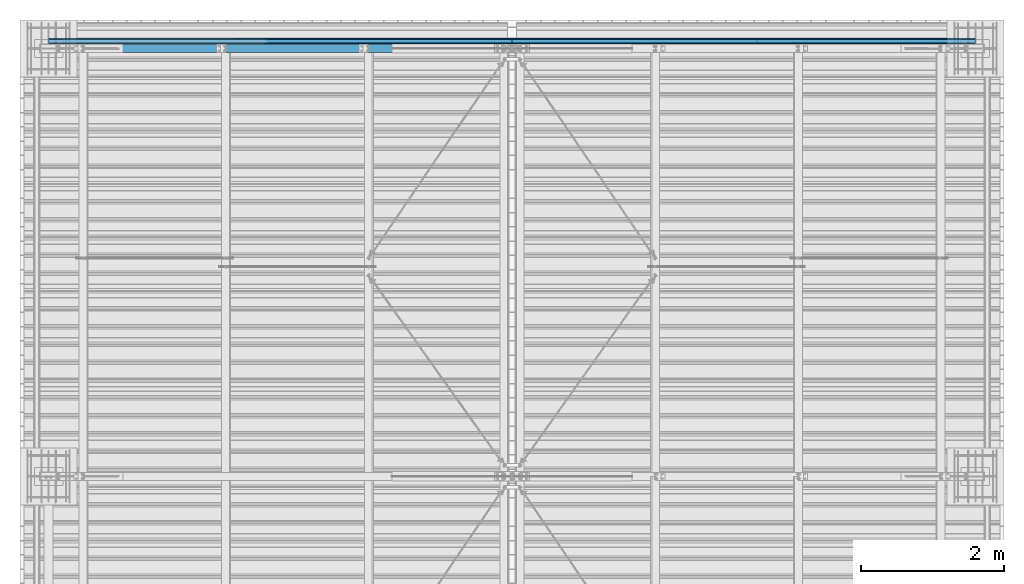
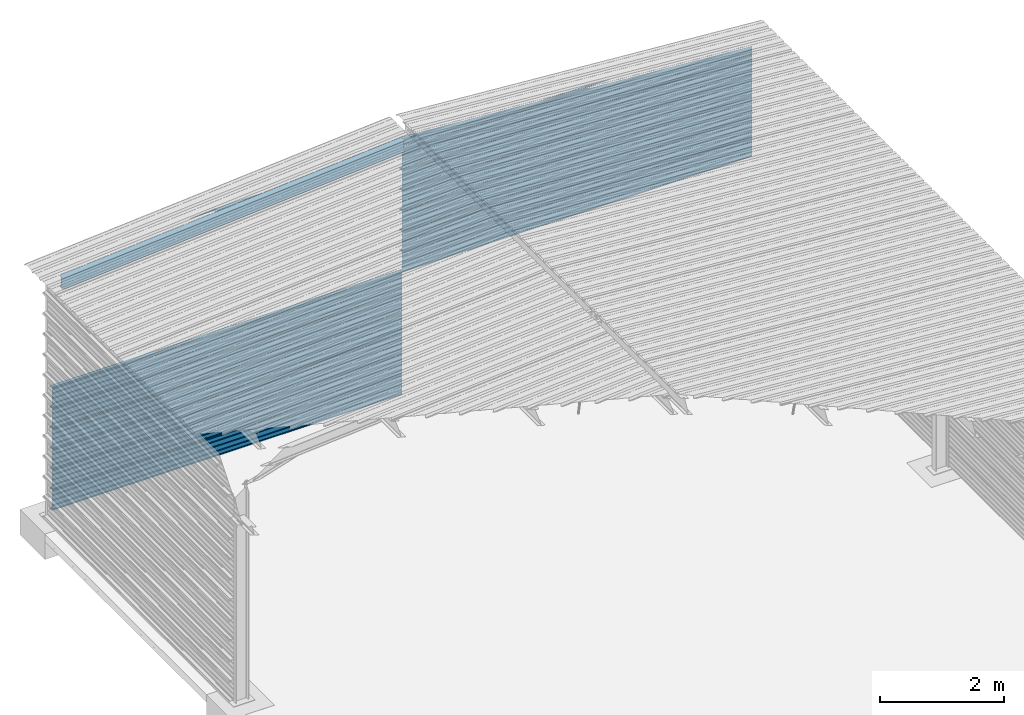
# One storey, part 20 of 70: 15 beams, 15 elements without a shape of their own.
"""IFC2X3 building model written with IfcOpenShell, lengths in millimetres."""

from ifc_helpers import new_model, si_unit, frame, origin_with_axes, origin_2d_with_axis, place, context, subcontext, project, spatial, polyline, i_section, outline, extrude, clip, halfspace, material, type_object, element, aggregate, save


model = new_model("IFC2X3")

# Units and contexts
model_context = context("Model", 3, precision=1e-05, world=origin_with_axes())
body_context = subcontext(model_context, "Body", "Model", "MODEL_VIEW")
ifc_project = project(units=[si_unit("LENGTHUNIT", "METRE", prefix="MILLI"), si_unit("AREAUNIT", "SQUARE_METRE"), si_unit("VOLUMEUNIT", "CUBIC_METRE"), si_unit("MASSUNIT", "GRAM", prefix="KILO"), si_unit("TIMEUNIT", "SECOND"), si_unit("PLANEANGLEUNIT", "RADIAN"), si_unit("SOLIDANGLEUNIT", "STERADIAN"), si_unit("THERMODYNAMICTEMPERATUREUNIT", "DEGREE_CELSIUS"), si_unit("LUMINOUSINTENSITYUNIT", "LUMEN")], contexts=[model_context])

# Site, building, storey
site_placement = place(None, origin_with_axes())
site = spatial("IfcSite", under=ifc_project, at=site_placement, CompositionType="ELEMENT")
building_placement = place(site_placement, origin_with_axes())
building = spatial("IfcBuilding", under=site, at=building_placement, Name="Undefined", CompositionType="ELEMENT")
storey_placement = place(building_placement, origin_with_axes())
storey = spatial("IfcBuildingStorey", under=building, at=storey_placement, Name="Undefined", CompositionType="ELEMENT", Elevation=0.0)

# Assembly, beam
assembly_1_placement = place(storey_placement, origin_with_axes())
assembly_1 = element("IfcElementAssembly", 1, at=assembly_1_placement, inside=storey, Name="Steel Assembly", AssemblyPlace="NOTDEFINED", PredefinedType="RIGID_FRAME")
ifc_material = material(Name="STEEL/S235JR")
beam_type_1 = type_object("IfcBeamType", Name="400", PredefinedType="NOTDEFINED")
beam_1_placement = place(assembly_1_placement, frame((0.0, 24105.5035213674, 5018.25), z_axis=(0.0, 1.0, 0.0), x_axis=(1.0, 0.0, 0.0)))
beam_1 = element("IfcBeam", 2, at=beam_1_placement, type_object=beam_type_1, material=ifc_material, ObjectType="400", context=body_context, shape_type="Clipping", body=[
    clip(extrude(outline(polyline([(218.25, -24.994083404541), (214.25, -31.8999996185303), (214.25, -45.5), (199.75, -45.5), (194.25, -42.5), (188.75, -45.5), (124.25, -45.5), (114.25, -41.5), (104.25, -45.5), (24.25, -45.5), (14.25, -41.5), (4.25, -45.5), (-75.75, -45.5), (-85.75, -41.5), (-95.75, -45.5), (-160.25, -45.5), (-165.75, -42.5), (-171.25, -45.5), (-185.75, -45.5), (-185.75, -30.711540222168), (-181.75, -23.8111782073975), (-181.75, 23.311637878418), (-185.75, 30.2119998931885), (-185.75, 44.5), (-217.25, 44.5), (-217.25, 34.7999992370605), (-218.25, 34.7999992370605), (-218.25, 45.5), (-184.75, 45.5), (-184.75, 30.480884552002), (-180.75, 23.5805225372314), (-180.75, -24.0800628662109), (-184.75, -30.9804248809814), (-184.75, -44.5), (-171.504989624023, -44.5), (-165.75, -41.360912322998), (-159.995010375977, -44.5), (-95.9425811767578, -44.5), (-85.75, -40.422966003418), (-75.5574188232422, -44.5), (4.05741739273071, -44.5), (14.25, -40.422966003418), (24.4425830841064, -44.5), (104.057418823242, -44.5), (114.25, -40.422966003418), (124.442581176758, -44.5), (188.495010375977, -44.5), (194.25, -41.360912322998), (200.004989624023, -44.5), (213.25, -44.5), (213.25, -31.6313018798828), (217.25, -24.7253856658936), (217.25, 21.7253856658936), (213.25, 28.6313018798828), (213.25, 42.0), (187.25, 42.0), (187.25, 32.5499992370605), (186.25, 32.5499992370605), (186.25, 43.0), (214.25, 43.0), (214.25, 28.8999996185303), (218.25, 21.994083404541), (218.25, -24.994083404541)])), frame((6500.0, 0.0, 0.0), z_axis=(-1.0, 0.0, 0.0), x_axis=(0.0, -1.0, 0.0)), (0.0, 0.0, 1.0), 6500.0), halfspace(frame((0.0, 418.250001003011, -45.0), z_axis=(-0.0766964990376778, -0.997054485489817, 0.0), x_axis=(0.0, 0.0, 1.0)), False)),
])
aggregate(assembly_1, [beam_1])

assembly_2_placement = place(storey_placement, origin_with_axes())
assembly_2 = element("IfcElementAssembly", 3, at=assembly_2_placement, inside=storey, Name="Steel Assembly", AssemblyPlace="NOTDEFINED", PredefinedType="RIGID_FRAME")
beam_2_placement = place(assembly_2_placement, frame((0.0, 24105.5035213674, 2218.25), z_axis=(0.0, 1.0, 0.0), x_axis=(1.0, 0.0, 0.0)))
beam_2 = element("IfcBeam", 4, at=beam_2_placement, type_object=beam_type_1, material=ifc_material, ObjectType="400", context=body_context, shape_type="SweptSolid", body=[
    extrude(outline(polyline([(218.25, -24.994083404541), (214.25, -31.8999996185303), (214.25, -45.5), (199.75, -45.5), (194.25, -42.5), (188.75, -45.5), (124.25, -45.5), (114.25, -41.5), (104.25, -45.5), (24.25, -45.5), (14.25, -41.5), (4.25, -45.5), (-75.75, -45.5), (-85.75, -41.5), (-95.75, -45.5), (-160.25, -45.5), (-165.75, -42.5), (-171.25, -45.5), (-185.75, -45.5), (-185.75, -30.711540222168), (-181.75, -23.8111782073975), (-181.75, 23.311637878418), (-185.75, 30.2119998931885), (-185.75, 44.5), (-217.25, 44.5), (-217.25, 34.7999992370605), (-218.25, 34.7999992370605), (-218.25, 45.5), (-184.75, 45.5), (-184.75, 30.480884552002), (-180.75, 23.5805225372314), (-180.75, -24.0800628662109), (-184.75, -30.9804248809814), (-184.75, -44.5), (-171.504989624023, -44.5), (-165.75, -41.360912322998), (-159.995010375977, -44.5), (-95.9425811767578, -44.5), (-85.75, -40.422966003418), (-75.5574188232422, -44.5), (4.05741739273071, -44.5), (14.25, -40.422966003418), (24.4425830841064, -44.5), (104.057418823242, -44.5), (114.25, -40.422966003418), (124.442581176758, -44.5), (188.495010375977, -44.5), (194.25, -41.360912322998), (200.004989624023, -44.5), (213.25, -44.5), (213.25, -31.6313018798828), (217.25, -24.7253856658936), (217.25, 21.7253856658936), (213.25, 28.6313018798828), (213.25, 42.0), (187.25, 42.0), (187.25, 32.5499992370605), (186.25, 32.5499992370605), (186.25, 43.0), (214.25, 43.0), (214.25, 28.8999996185303), (218.25, 21.994083404541), (218.25, -24.994083404541)])), frame((6500.0, 0.0, 0.0), z_axis=(-1.0, 0.0, 0.0), x_axis=(0.0, -1.0, 0.0)), (0.0, 0.0, 1.0), 6500.0),
])
aggregate(assembly_2, [beam_2])

assembly_3_placement = place(storey_placement, origin_with_axes())
assembly_3 = element("IfcElementAssembly", 5, at=assembly_3_placement, inside=storey, Name="Steel Assembly", AssemblyPlace="NOTDEFINED", PredefinedType="RIGID_FRAME")
beam_3_placement = place(assembly_3_placement, frame((0.0, 24105.5035213674, 1818.25), z_axis=(0.0, 1.0, 0.0), x_axis=(1.0, 0.0, 0.0)))
beam_3 = element("IfcBeam", 6, at=beam_3_placement, type_object=beam_type_1, material=ifc_material, ObjectType="400", context=body_context, shape_type="SweptSolid", body=[
    extrude(outline(polyline([(218.25, -24.994083404541), (214.25, -31.8999996185303), (214.25, -45.5), (199.75, -45.5), (194.25, -42.5), (188.75, -45.5), (124.25, -45.5), (114.25, -41.5), (104.25, -45.5), (24.25, -45.5), (14.25, -41.5), (4.25, -45.5), (-75.75, -45.5), (-85.75, -41.5), (-95.75, -45.5), (-160.25, -45.5), (-165.75, -42.5), (-171.25, -45.5), (-185.75, -45.5), (-185.75, -30.711540222168), (-181.75, -23.8111782073975), (-181.75, 23.311637878418), (-185.75, 30.2119998931885), (-185.75, 44.5), (-217.25, 44.5), (-217.25, 34.7999992370605), (-218.25, 34.7999992370605), (-218.25, 45.5), (-184.75, 45.5), (-184.75, 30.480884552002), (-180.75, 23.5805225372314), (-180.75, -24.0800628662109), (-184.75, -30.9804248809814), (-184.75, -44.5), (-171.504989624023, -44.5), (-165.75, -41.360912322998), (-159.995010375977, -44.5), (-95.9425811767578, -44.5), (-85.75, -40.422966003418), (-75.5574188232422, -44.5), (4.05741739273071, -44.5), (14.25, -40.422966003418), (24.4425830841064, -44.5), (104.057418823242, -44.5), (114.25, -40.422966003418), (124.442581176758, -44.5), (188.495010375977, -44.5), (194.25, -41.360912322998), (200.004989624023, -44.5), (213.25, -44.5), (213.25, -31.6313018798828), (217.25, -24.7253856658936), (217.25, 21.7253856658936), (213.25, 28.6313018798828), (213.25, 42.0), (187.25, 42.0), (187.25, 32.5499992370605), (186.25, 32.5499992370605), (186.25, 43.0), (214.25, 43.0), (214.25, 28.8999996185303), (218.25, 21.994083404541), (218.25, -24.994083404541)])), frame((6500.0, 0.0, 0.0), z_axis=(-1.0, 0.0, 0.0), x_axis=(0.0, -1.0, 0.0)), (0.0, 0.0, 1.0), 6500.0),
])
aggregate(assembly_3, [beam_3])

assembly_4_placement = place(storey_placement, origin_with_axes())
assembly_4 = element("IfcElementAssembly", 7, at=assembly_4_placement, inside=storey, Name="Steel Assembly", AssemblyPlace="NOTDEFINED", PredefinedType="RIGID_FRAME")
beam_4_placement = place(assembly_4_placement, frame((0.0, 24105.5035213674, 1418.25), z_axis=(0.0, 1.0, 0.0), x_axis=(1.0, 0.0, 0.0)))
beam_4 = element("IfcBeam", 8, at=beam_4_placement, type_object=beam_type_1, material=ifc_material, ObjectType="400", context=body_context, shape_type="SweptSolid", body=[
    extrude(outline(polyline([(218.25, -24.994083404541), (214.25, -31.8999996185303), (214.25, -45.5), (199.75, -45.5), (194.25, -42.5), (188.75, -45.5), (124.25, -45.5), (114.25, -41.5), (104.25, -45.5), (24.25, -45.5), (14.25, -41.5), (4.25, -45.5), (-75.75, -45.5), (-85.75, -41.5), (-95.75, -45.5), (-160.25, -45.5), (-165.75, -42.5), (-171.25, -45.5), (-185.75, -45.5), (-185.75, -30.711540222168), (-181.75, -23.8111782073975), (-181.75, 23.311637878418), (-185.75, 30.2119998931885), (-185.75, 44.5), (-217.25, 44.5), (-217.25, 34.7999992370605), (-218.25, 34.7999992370605), (-218.25, 45.5), (-184.75, 45.5), (-184.75, 30.480884552002), (-180.75, 23.5805225372314), (-180.75, -24.0800628662109), (-184.75, -30.9804248809814), (-184.75, -44.5), (-171.504989624023, -44.5), (-165.75, -41.360912322998), (-159.995010375977, -44.5), (-95.9425811767578, -44.5), (-85.75, -40.422966003418), (-75.5574188232422, -44.5), (4.05741739273071, -44.5), (14.25, -40.422966003418), (24.4425830841064, -44.5), (104.057418823242, -44.5), (114.25, -40.422966003418), (124.442581176758, -44.5), (188.495010375977, -44.5), (194.25, -41.360912322998), (200.004989624023, -44.5), (213.25, -44.5), (213.25, -31.6313018798828), (217.25, -24.7253856658936), (217.25, 21.7253856658936), (213.25, 28.6313018798828), (213.25, 42.0), (187.25, 42.0), (187.25, 32.5499992370605), (186.25, 32.5499992370605), (186.25, 43.0), (214.25, 43.0), (214.25, 28.8999996185303), (218.25, 21.994083404541), (218.25, -24.994083404541)])), frame((6500.0, 0.0, 0.0), z_axis=(-1.0, 0.0, 0.0), x_axis=(0.0, -1.0, 0.0)), (0.0, 0.0, 1.0), 6500.0),
])
aggregate(assembly_4, [beam_4])

assembly_5_placement = place(storey_placement, origin_with_axes())
assembly_5 = element("IfcElementAssembly", 9, at=assembly_5_placement, inside=storey, Name="Steel Assembly", AssemblyPlace="NOTDEFINED", PredefinedType="RIGID_FRAME")
beam_5_placement = place(assembly_5_placement, frame((0.0, 24105.5035213674, 1018.25), z_axis=(0.0, 1.0, 0.0), x_axis=(1.0, 0.0, 0.0)))
beam_5 = element("IfcBeam", 10, at=beam_5_placement, type_object=beam_type_1, material=ifc_material, ObjectType="400", context=body_context, shape_type="SweptSolid", body=[
    extrude(outline(polyline([(218.25, -24.994083404541), (214.25, -31.8999996185303), (214.25, -45.5), (199.75, -45.5), (194.25, -42.5), (188.75, -45.5), (124.25, -45.5), (114.25, -41.5), (104.25, -45.5), (24.25, -45.5), (14.25, -41.5), (4.25, -45.5), (-75.75, -45.5), (-85.75, -41.5), (-95.75, -45.5), (-160.25, -45.5), (-165.75, -42.5), (-171.25, -45.5), (-185.75, -45.5), (-185.75, -30.711540222168), (-181.75, -23.8111782073975), (-181.75, 23.311637878418), (-185.75, 30.2119998931885), (-185.75, 44.5), (-217.25, 44.5), (-217.25, 34.7999992370605), (-218.25, 34.7999992370605), (-218.25, 45.5), (-184.75, 45.5), (-184.75, 30.480884552002), (-180.75, 23.5805225372314), (-180.75, -24.0800628662109), (-184.75, -30.9804248809814), (-184.75, -44.5), (-171.504989624023, -44.5), (-165.75, -41.360912322998), (-159.995010375977, -44.5), (-95.9425811767578, -44.5), (-85.75, -40.422966003418), (-75.5574188232422, -44.5), (4.05741739273071, -44.5), (14.25, -40.422966003418), (24.4425830841064, -44.5), (104.057418823242, -44.5), (114.25, -40.422966003418), (124.442581176758, -44.5), (188.495010375977, -44.5), (194.25, -41.360912322998), (200.004989624023, -44.5), (213.25, -44.5), (213.25, -31.6313018798828), (217.25, -24.7253856658936), (217.25, 21.7253856658936), (213.25, 28.6313018798828), (213.25, 42.0), (187.25, 42.0), (187.25, 32.5499992370605), (186.25, 32.5499992370605), (186.25, 43.0), (214.25, 43.0), (214.25, 28.8999996185303), (218.25, 21.994083404541), (218.25, -24.994083404541)])), frame((6500.0, 0.0, 0.0), z_axis=(-1.0, 0.0, 0.0), x_axis=(0.0, -1.0, 0.0)), (0.0, 0.0, 1.0), 6500.0),
])
aggregate(assembly_5, [beam_5])

assembly_6_placement = place(storey_placement, origin_with_axes())
assembly_6 = element("IfcElementAssembly", 11, at=assembly_6_placement, inside=storey, Name="Steel Assembly", AssemblyPlace="NOTDEFINED", PredefinedType="RIGID_FRAME")
beam_6_placement = place(assembly_6_placement, frame((0.0, 24105.5035213674, 618.25), z_axis=(0.0, 1.0, 0.0), x_axis=(1.0, 0.0, 0.0)))
beam_6 = element("IfcBeam", 12, at=beam_6_placement, type_object=beam_type_1, material=ifc_material, ObjectType="400", context=body_context, shape_type="SweptSolid", body=[
    extrude(outline(polyline([(218.25, -24.994083404541), (214.25, -31.8999996185303), (214.25, -45.5), (199.75, -45.5), (194.25, -42.5), (188.75, -45.5), (124.25, -45.5), (114.25, -41.5), (104.25, -45.5), (24.25, -45.5), (14.25, -41.5), (4.25, -45.5), (-75.75, -45.5), (-85.75, -41.5), (-95.75, -45.5), (-160.25, -45.5), (-165.75, -42.5), (-171.25, -45.5), (-185.75, -45.5), (-185.75, -30.711540222168), (-181.75, -23.8111782073975), (-181.75, 23.311637878418), (-185.75, 30.2119998931885), (-185.75, 44.5), (-217.25, 44.5), (-217.25, 34.7999992370605), (-218.25, 34.7999992370605), (-218.25, 45.5), (-184.75, 45.5), (-184.75, 30.480884552002), (-180.75, 23.5805225372314), (-180.75, -24.0800628662109), (-184.75, -30.9804248809814), (-184.75, -44.5), (-171.504989624023, -44.5), (-165.75, -41.360912322998), (-159.995010375977, -44.5), (-95.9425811767578, -44.5), (-85.75, -40.422966003418), (-75.5574188232422, -44.5), (4.05741739273071, -44.5), (14.25, -40.422966003418), (24.4425830841064, -44.5), (104.057418823242, -44.5), (114.25, -40.422966003418), (124.442581176758, -44.5), (188.495010375977, -44.5), (194.25, -41.360912322998), (200.004989624023, -44.5), (213.25, -44.5), (213.25, -31.6313018798828), (217.25, -24.7253856658936), (217.25, 21.7253856658936), (213.25, 28.6313018798828), (213.25, 42.0), (187.25, 42.0), (187.25, 32.5499992370605), (186.25, 32.5499992370605), (186.25, 43.0), (214.25, 43.0), (214.25, 28.8999996185303), (218.25, 21.994083404541), (218.25, -24.994083404541)])), frame((6500.0, 0.0, 0.0), z_axis=(-1.0, 0.0, 0.0), x_axis=(0.0, -1.0, 0.0)), (0.0, 0.0, 1.0), 6500.0),
])
aggregate(assembly_6, [beam_6])

assembly_7_placement = place(storey_placement, origin_with_axes())
assembly_7 = element("IfcElementAssembly", 13, at=assembly_7_placement, inside=storey, Name="Steel Assembly", AssemblyPlace="NOTDEFINED", PredefinedType="RIGID_FRAME")
beam_7_placement = place(assembly_7_placement, frame((0.0, 24105.5035213674, 218.25), z_axis=(0.0, 1.0, 0.0), x_axis=(1.0, 0.0, 0.0)))
beam_7 = element("IfcBeam", 14, at=beam_7_placement, type_object=beam_type_1, material=ifc_material, ObjectType="400", context=body_context, shape_type="SweptSolid", body=[
    extrude(outline(polyline([(218.25, -24.994083404541), (214.25, -31.8999996185303), (214.25, -45.5), (199.75, -45.5), (194.25, -42.5), (188.75, -45.5), (124.25, -45.5), (114.25, -41.5), (104.25, -45.5), (24.25, -45.5), (14.25, -41.5), (4.25, -45.5), (-75.75, -45.5), (-85.75, -41.5), (-95.75, -45.5), (-160.25, -45.5), (-165.75, -42.5), (-171.25, -45.5), (-185.75, -45.5), (-185.75, -30.711540222168), (-181.75, -23.8111782073975), (-181.75, 23.311637878418), (-185.75, 30.2119998931885), (-185.75, 44.5), (-217.25, 44.5), (-217.25, 34.7999992370605), (-218.25, 34.7999992370605), (-218.25, 45.5), (-184.75, 45.5), (-184.75, 30.480884552002), (-180.75, 23.5805225372314), (-180.75, -24.0800628662109), (-184.75, -30.9804248809814), (-184.75, -44.5), (-171.504989624023, -44.5), (-165.75, -41.360912322998), (-159.995010375977, -44.5), (-95.9425811767578, -44.5), (-85.75, -40.422966003418), (-75.5574188232422, -44.5), (4.05741739273071, -44.5), (14.25, -40.422966003418), (24.4425830841064, -44.5), (104.057418823242, -44.5), (114.25, -40.422966003418), (124.442581176758, -44.5), (188.495010375977, -44.5), (194.25, -41.360912322998), (200.004989624023, -44.5), (213.25, -44.5), (213.25, -31.6313018798828), (217.25, -24.7253856658936), (217.25, 21.7253856658936), (213.25, 28.6313018798828), (213.25, 42.0), (187.25, 42.0), (187.25, 32.5499992370605), (186.25, 32.5499992370605), (186.25, 43.0), (214.25, 43.0), (214.25, 28.8999996185303), (218.25, 21.994083404541), (218.25, -24.994083404541)])), frame((6500.0, 0.0, 0.0), z_axis=(-1.0, 0.0, 0.0), x_axis=(0.0, -1.0, 0.0)), (0.0, 0.0, 1.0), 6500.0),
])
aggregate(assembly_7, [beam_7])

assembly_8_placement = place(storey_placement, origin_with_axes())
assembly_8 = element("IfcElementAssembly", 15, at=assembly_8_placement, inside=storey, Name="Steel Assembly", AssemblyPlace="NOTDEFINED", PredefinedType="RIGID_FRAME")
beam_8_placement = place(assembly_8_placement, frame((6500.0, 24105.5035213674, 5018.25), z_axis=(0.0, 1.0, 0.0), x_axis=(1.0, 0.0, 0.0)))
beam_8 = element("IfcBeam", 16, at=beam_8_placement, type_object=beam_type_1, material=ifc_material, ObjectType="400", context=body_context, shape_type="Clipping", body=[
    clip(extrude(outline(polyline([(218.25, -24.994083404541), (214.25, -31.8999996185303), (214.25, -45.5), (199.75, -45.5), (194.25, -42.5), (188.75, -45.5), (124.25, -45.5), (114.25, -41.5), (104.25, -45.5), (24.25, -45.5), (14.25, -41.5), (4.25, -45.5), (-75.75, -45.5), (-85.75, -41.5), (-95.75, -45.5), (-160.25, -45.5), (-165.75, -42.5), (-171.25, -45.5), (-185.75, -45.5), (-185.75, -30.711540222168), (-181.75, -23.8111782073975), (-181.75, 23.311637878418), (-185.75, 30.2119998931885), (-185.75, 44.5), (-217.25, 44.5), (-217.25, 34.7999992370605), (-218.25, 34.7999992370605), (-218.25, 45.5), (-184.75, 45.5), (-184.75, 30.480884552002), (-180.75, 23.5805225372314), (-180.75, -24.0800628662109), (-184.75, -30.9804248809814), (-184.75, -44.5), (-171.504989624023, -44.5), (-165.75, -41.360912322998), (-159.995010375977, -44.5), (-95.9425811767578, -44.5), (-85.75, -40.422966003418), (-75.5574188232422, -44.5), (4.05741739273071, -44.5), (14.25, -40.422966003418), (24.4425830841064, -44.5), (104.057418823242, -44.5), (114.25, -40.422966003418), (124.442581176758, -44.5), (188.495010375977, -44.5), (194.25, -41.360912322998), (200.004989624023, -44.5), (213.25, -44.5), (213.25, -31.6313018798828), (217.25, -24.7253856658936), (217.25, 21.7253856658936), (213.25, 28.6313018798828), (213.25, 42.0), (187.25, 42.0), (187.25, 32.5499992370605), (186.25, 32.5499992370605), (186.25, 43.0), (214.25, 43.0), (214.25, 28.8999996185303), (218.25, 21.994083404541), (218.25, -24.994083404541)])), frame((6500.0, 0.0, 0.0), z_axis=(-1.0, 0.0, 0.0), x_axis=(0.0, -1.0, 0.0)), (0.0, 0.0, 1.0), 6500.0), halfspace(frame((6500.0, 418.250001003011, -45.0), z_axis=(0.0766964990376779, -0.997054485489817, 0.0), x_axis=(-0.997054485489817, -0.0766964990376779, 0.0)), False)),
])
aggregate(assembly_8, [beam_8])

assembly_9_placement = place(storey_placement, origin_with_axes())
assembly_9 = element("IfcElementAssembly", 17, at=assembly_9_placement, inside=storey, Name="Steel Assembly", AssemblyPlace="NOTDEFINED", PredefinedType="RIGID_FRAME")
beam_9_placement = place(assembly_9_placement, frame((6500.0, 24105.5035213674, 4618.25), z_axis=(0.0, 1.0, 0.0), x_axis=(1.0, 0.0, 0.0)))
beam_9 = element("IfcBeam", 18, at=beam_9_placement, type_object=beam_type_1, material=ifc_material, ObjectType="400", context=body_context, shape_type="Clipping", body=[
    clip(extrude(outline(polyline([(218.25, -24.994083404541), (214.25, -31.8999996185303), (214.25, -45.5), (199.75, -45.5), (194.25, -42.5), (188.75, -45.5), (124.25, -45.5), (114.25, -41.5), (104.25, -45.5), (24.25, -45.5), (14.25, -41.5), (4.25, -45.5), (-75.75, -45.5), (-85.75, -41.5), (-95.75, -45.5), (-160.25, -45.5), (-165.75, -42.5), (-171.25, -45.5), (-185.75, -45.5), (-185.75, -30.711540222168), (-181.75, -23.8111782073975), (-181.75, 23.311637878418), (-185.75, 30.2119998931885), (-185.75, 44.5), (-217.25, 44.5), (-217.25, 34.7999992370605), (-218.25, 34.7999992370605), (-218.25, 45.5), (-184.75, 45.5), (-184.75, 30.480884552002), (-180.75, 23.5805225372314), (-180.75, -24.0800628662109), (-184.75, -30.9804248809814), (-184.75, -44.5), (-171.504989624023, -44.5), (-165.75, -41.360912322998), (-159.995010375977, -44.5), (-95.9425811767578, -44.5), (-85.75, -40.422966003418), (-75.5574188232422, -44.5), (4.05741739273071, -44.5), (14.25, -40.422966003418), (24.4425830841064, -44.5), (104.057418823242, -44.5), (114.25, -40.422966003418), (124.442581176758, -44.5), (188.495010375977, -44.5), (194.25, -41.360912322998), (200.004989624023, -44.5), (213.25, -44.5), (213.25, -31.6313018798828), (217.25, -24.7253856658936), (217.25, 21.7253856658936), (213.25, 28.6313018798828), (213.25, 42.0), (187.25, 42.0), (187.25, 32.5499992370605), (186.25, 32.5499992370605), (186.25, 43.0), (214.25, 43.0), (214.25, 28.8999996185303), (218.25, 21.994083404541), (218.25, -24.994083404541)])), frame((6500.0, 0.0, 0.0), z_axis=(-1.0, 0.0, 0.0), x_axis=(0.0, -1.0, 0.0)), (0.0, 0.0, 1.0), 6500.0), halfspace(frame((6500.0, 18.2500010030071, -45.0), z_axis=(0.0766964990376779, -0.997054485489817, 0.0), x_axis=(-0.997054485489817, -0.0766964990376779, 0.0)), False)),
])
aggregate(assembly_9, [beam_9])

assembly_10_placement = place(storey_placement, origin_with_axes())
assembly_10 = element("IfcElementAssembly", 19, at=assembly_10_placement, inside=storey, Name="Steel Assembly", AssemblyPlace="NOTDEFINED", PredefinedType="RIGID_FRAME")
beam_10_placement = place(assembly_10_placement, frame((6500.0, 24105.5035213674, 4218.25), z_axis=(0.0, 1.0, 0.0), x_axis=(1.0, 0.0, 0.0)))
beam_10 = element("IfcBeam", 20, at=beam_10_placement, type_object=beam_type_1, material=ifc_material, ObjectType="400", context=body_context, shape_type="SweptSolid", body=[
    extrude(outline(polyline([(218.25, -24.994083404541), (214.25, -31.8999996185303), (214.25, -45.5), (199.75, -45.5), (194.25, -42.5), (188.75, -45.5), (124.25, -45.5), (114.25, -41.5), (104.25, -45.5), (24.25, -45.5), (14.25, -41.5), (4.25, -45.5), (-75.75, -45.5), (-85.75, -41.5), (-95.75, -45.5), (-160.25, -45.5), (-165.75, -42.5), (-171.25, -45.5), (-185.75, -45.5), (-185.75, -30.711540222168), (-181.75, -23.8111782073975), (-181.75, 23.311637878418), (-185.75, 30.2119998931885), (-185.75, 44.5), (-217.25, 44.5), (-217.25, 34.7999992370605), (-218.25, 34.7999992370605), (-218.25, 45.5), (-184.75, 45.5), (-184.75, 30.480884552002), (-180.75, 23.5805225372314), (-180.75, -24.0800628662109), (-184.75, -30.9804248809814), (-184.75, -44.5), (-171.504989624023, -44.5), (-165.75, -41.360912322998), (-159.995010375977, -44.5), (-95.9425811767578, -44.5), (-85.75, -40.422966003418), (-75.5574188232422, -44.5), (4.05741739273071, -44.5), (14.25, -40.422966003418), (24.4425830841064, -44.5), (104.057418823242, -44.5), (114.25, -40.422966003418), (124.442581176758, -44.5), (188.495010375977, -44.5), (194.25, -41.360912322998), (200.004989624023, -44.5), (213.25, -44.5), (213.25, -31.6313018798828), (217.25, -24.7253856658936), (217.25, 21.7253856658936), (213.25, 28.6313018798828), (213.25, 42.0), (187.25, 42.0), (187.25, 32.5499992370605), (186.25, 32.5499992370605), (186.25, 43.0), (214.25, 43.0), (214.25, 28.8999996185303), (218.25, 21.994083404541), (218.25, -24.994083404541)])), frame((6500.0, 0.0, 0.0), z_axis=(-1.0, 0.0, 0.0), x_axis=(0.0, -1.0, 0.0)), (0.0, 0.0, 1.0), 6500.0),
])
aggregate(assembly_10, [beam_10])

assembly_11_placement = place(storey_placement, origin_with_axes())
assembly_11 = element("IfcElementAssembly", 21, at=assembly_11_placement, inside=storey, Name="Steel Assembly", AssemblyPlace="NOTDEFINED", PredefinedType="RIGID_FRAME")
beam_11_placement = place(assembly_11_placement, frame((6500.0, 24105.5035213674, 3818.25), z_axis=(0.0, 1.0, 0.0), x_axis=(1.0, 0.0, 0.0)))
beam_11 = element("IfcBeam", 22, at=beam_11_placement, type_object=beam_type_1, material=ifc_material, ObjectType="400", context=body_context, shape_type="SweptSolid", body=[
    extrude(outline(polyline([(218.25, -24.994083404541), (214.25, -31.8999996185303), (214.25, -45.5), (199.75, -45.5), (194.25, -42.5), (188.75, -45.5), (124.25, -45.5), (114.25, -41.5), (104.25, -45.5), (24.25, -45.5), (14.25, -41.5), (4.25, -45.5), (-75.75, -45.5), (-85.75, -41.5), (-95.75, -45.5), (-160.25, -45.5), (-165.75, -42.5), (-171.25, -45.5), (-185.75, -45.5), (-185.75, -30.711540222168), (-181.75, -23.8111782073975), (-181.75, 23.311637878418), (-185.75, 30.2119998931885), (-185.75, 44.5), (-217.25, 44.5), (-217.25, 34.7999992370605), (-218.25, 34.7999992370605), (-218.25, 45.5), (-184.75, 45.5), (-184.75, 30.480884552002), (-180.75, 23.5805225372314), (-180.75, -24.0800628662109), (-184.75, -30.9804248809814), (-184.75, -44.5), (-171.504989624023, -44.5), (-165.75, -41.360912322998), (-159.995010375977, -44.5), (-95.9425811767578, -44.5), (-85.75, -40.422966003418), (-75.5574188232422, -44.5), (4.05741739273071, -44.5), (14.25, -40.422966003418), (24.4425830841064, -44.5), (104.057418823242, -44.5), (114.25, -40.422966003418), (124.442581176758, -44.5), (188.495010375977, -44.5), (194.25, -41.360912322998), (200.004989624023, -44.5), (213.25, -44.5), (213.25, -31.6313018798828), (217.25, -24.7253856658936), (217.25, 21.7253856658936), (213.25, 28.6313018798828), (213.25, 42.0), (187.25, 42.0), (187.25, 32.5499992370605), (186.25, 32.5499992370605), (186.25, 43.0), (214.25, 43.0), (214.25, 28.8999996185303), (218.25, 21.994083404541), (218.25, -24.994083404541)])), frame((6500.0, 0.0, 0.0), z_axis=(-1.0, 0.0, 0.0), x_axis=(0.0, -1.0, 0.0)), (0.0, 0.0, 1.0), 6500.0),
])
aggregate(assembly_11, [beam_11])

assembly_12_placement = place(storey_placement, origin_with_axes())
assembly_12 = element("IfcElementAssembly", 23, at=assembly_12_placement, inside=storey, Name="Steel Assembly", AssemblyPlace="NOTDEFINED", PredefinedType="RIGID_FRAME")
beam_12_placement = place(assembly_12_placement, frame((6500.0, 24105.5035213674, 3418.25), z_axis=(0.0, 1.0, 0.0), x_axis=(1.0, 0.0, 0.0)))
beam_12 = element("IfcBeam", 24, at=beam_12_placement, type_object=beam_type_1, material=ifc_material, ObjectType="400", context=body_context, shape_type="SweptSolid", body=[
    extrude(outline(polyline([(218.25, -24.994083404541), (214.25, -31.8999996185303), (214.25, -45.5), (199.75, -45.5), (194.25, -42.5), (188.75, -45.5), (124.25, -45.5), (114.25, -41.5), (104.25, -45.5), (24.25, -45.5), (14.25, -41.5), (4.25, -45.5), (-75.75, -45.5), (-85.75, -41.5), (-95.75, -45.5), (-160.25, -45.5), (-165.75, -42.5), (-171.25, -45.5), (-185.75, -45.5), (-185.75, -30.711540222168), (-181.75, -23.8111782073975), (-181.75, 23.311637878418), (-185.75, 30.2119998931885), (-185.75, 44.5), (-217.25, 44.5), (-217.25, 34.7999992370605), (-218.25, 34.7999992370605), (-218.25, 45.5), (-184.75, 45.5), (-184.75, 30.480884552002), (-180.75, 23.5805225372314), (-180.75, -24.0800628662109), (-184.75, -30.9804248809814), (-184.75, -44.5), (-171.504989624023, -44.5), (-165.75, -41.360912322998), (-159.995010375977, -44.5), (-95.9425811767578, -44.5), (-85.75, -40.422966003418), (-75.5574188232422, -44.5), (4.05741739273071, -44.5), (14.25, -40.422966003418), (24.4425830841064, -44.5), (104.057418823242, -44.5), (114.25, -40.422966003418), (124.442581176758, -44.5), (188.495010375977, -44.5), (194.25, -41.360912322998), (200.004989624023, -44.5), (213.25, -44.5), (213.25, -31.6313018798828), (217.25, -24.7253856658936), (217.25, 21.7253856658936), (213.25, 28.6313018798828), (213.25, 42.0), (187.25, 42.0), (187.25, 32.5499992370605), (186.25, 32.5499992370605), (186.25, 43.0), (214.25, 43.0), (214.25, 28.8999996185303), (218.25, 21.994083404541), (218.25, -24.994083404541)])), frame((6500.0, 0.0, 0.0), z_axis=(-1.0, 0.0, 0.0), x_axis=(0.0, -1.0, 0.0)), (0.0, 0.0, 1.0), 6500.0),
])
aggregate(assembly_12, [beam_12])

assembly_13_placement = place(storey_placement, origin_with_axes())
assembly_13 = element("IfcElementAssembly", 25, at=assembly_13_placement, inside=storey, Name="Steel Assembly", AssemblyPlace="NOTDEFINED", PredefinedType="RIGID_FRAME")
beam_13_placement = place(assembly_13_placement, frame((6500.0, 24105.5035213674, 3018.25), z_axis=(0.0, 1.0, 0.0), x_axis=(1.0, 0.0, 0.0)))
beam_13 = element("IfcBeam", 26, at=beam_13_placement, type_object=beam_type_1, material=ifc_material, ObjectType="400", context=body_context, shape_type="SweptSolid", body=[
    extrude(outline(polyline([(218.25, -24.994083404541), (214.25, -31.8999996185303), (214.25, -45.5), (199.75, -45.5), (194.25, -42.5), (188.75, -45.5), (124.25, -45.5), (114.25, -41.5), (104.25, -45.5), (24.25, -45.5), (14.25, -41.5), (4.25, -45.5), (-75.75, -45.5), (-85.75, -41.5), (-95.75, -45.5), (-160.25, -45.5), (-165.75, -42.5), (-171.25, -45.5), (-185.75, -45.5), (-185.75, -30.711540222168), (-181.75, -23.8111782073975), (-181.75, 23.311637878418), (-185.75, 30.2119998931885), (-185.75, 44.5), (-217.25, 44.5), (-217.25, 34.7999992370605), (-218.25, 34.7999992370605), (-218.25, 45.5), (-184.75, 45.5), (-184.75, 30.480884552002), (-180.75, 23.5805225372314), (-180.75, -24.0800628662109), (-184.75, -30.9804248809814), (-184.75, -44.5), (-171.504989624023, -44.5), (-165.75, -41.360912322998), (-159.995010375977, -44.5), (-95.9425811767578, -44.5), (-85.75, -40.422966003418), (-75.5574188232422, -44.5), (4.05741739273071, -44.5), (14.25, -40.422966003418), (24.4425830841064, -44.5), (104.057418823242, -44.5), (114.25, -40.422966003418), (124.442581176758, -44.5), (188.495010375977, -44.5), (194.25, -41.360912322998), (200.004989624023, -44.5), (213.25, -44.5), (213.25, -31.6313018798828), (217.25, -24.7253856658936), (217.25, 21.7253856658936), (213.25, 28.6313018798828), (213.25, 42.0), (187.25, 42.0), (187.25, 32.5499992370605), (186.25, 32.5499992370605), (186.25, 43.0), (214.25, 43.0), (214.25, 28.8999996185303), (218.25, 21.994083404541), (218.25, -24.994083404541)])), frame((6500.0, 0.0, 0.0), z_axis=(-1.0, 0.0, 0.0), x_axis=(0.0, -1.0, 0.0)), (0.0, 0.0, 1.0), 6500.0),
])
aggregate(assembly_13, [beam_13])

assembly_14_placement = place(storey_placement, origin_with_axes())
assembly_14 = element("IfcElementAssembly", 27, at=assembly_14_placement, inside=storey, Name="Steel Assembly", AssemblyPlace="NOTDEFINED", PredefinedType="RIGID_FRAME")
beam_14_placement = place(assembly_14_placement, frame((6500.0, 24105.5035213674, 2618.25), z_axis=(0.0, 1.0, 0.0), x_axis=(1.0, 0.0, 0.0)))
beam_14 = element("IfcBeam", 28, at=beam_14_placement, type_object=beam_type_1, material=ifc_material, ObjectType="400", context=body_context, shape_type="SweptSolid", body=[
    extrude(outline(polyline([(218.25, -24.994083404541), (214.25, -31.8999996185303), (214.25, -45.5), (199.75, -45.5), (194.25, -42.5), (188.75, -45.5), (124.25, -45.5), (114.25, -41.5), (104.25, -45.5), (24.25, -45.5), (14.25, -41.5), (4.25, -45.5), (-75.75, -45.5), (-85.75, -41.5), (-95.75, -45.5), (-160.25, -45.5), (-165.75, -42.5), (-171.25, -45.5), (-185.75, -45.5), (-185.75, -30.711540222168), (-181.75, -23.8111782073975), (-181.75, 23.311637878418), (-185.75, 30.2119998931885), (-185.75, 44.5), (-217.25, 44.5), (-217.25, 34.7999992370605), (-218.25, 34.7999992370605), (-218.25, 45.5), (-184.75, 45.5), (-184.75, 30.480884552002), (-180.75, 23.5805225372314), (-180.75, -24.0800628662109), (-184.75, -30.9804248809814), (-184.75, -44.5), (-171.504989624023, -44.5), (-165.75, -41.360912322998), (-159.995010375977, -44.5), (-95.9425811767578, -44.5), (-85.75, -40.422966003418), (-75.5574188232422, -44.5), (4.05741739273071, -44.5), (14.25, -40.422966003418), (24.4425830841064, -44.5), (104.057418823242, -44.5), (114.25, -40.422966003418), (124.442581176758, -44.5), (188.495010375977, -44.5), (194.25, -41.360912322998), (200.004989624023, -44.5), (213.25, -44.5), (213.25, -31.6313018798828), (217.25, -24.7253856658936), (217.25, 21.7253856658936), (213.25, 28.6313018798828), (213.25, 42.0), (187.25, 42.0), (187.25, 32.5499992370605), (186.25, 32.5499992370605), (186.25, 43.0), (214.25, 43.0), (214.25, 28.8999996185303), (218.25, 21.994083404541), (218.25, -24.994083404541)])), frame((6500.0, 0.0, 0.0), z_axis=(-1.0, 0.0, 0.0), x_axis=(0.0, -1.0, 0.0)), (0.0, 0.0, 1.0), 6500.0),
])
aggregate(assembly_14, [beam_14])

assembly_15_placement = place(storey_placement, origin_with_axes())
assembly_15 = element("IfcElementAssembly", 29, at=assembly_15_placement, inside=storey, Name="Steel Assembly", AssemblyPlace="NOTDEFINED", PredefinedType="RIGID_FRAME")
beam_type_2 = type_object("IfcBeamType", Name="IPE220", PredefinedType="NOTDEFINED")
beam_15_placement = place(assembly_15_placement, frame((8.43661487722628, 24000.0, 4490.32400659478), z_axis=(-0.0766964990376602, 0.0, 0.997054485489818), x_axis=(0.997054485489816, 0.0, 0.0766964990376847)))
beam_15 = element("IfcBeam", 30, at=beam_15_placement, type_object=beam_type_2, material=ifc_material, Name="POUTRE", ObjectType="IPE220", context=body_context, shape_type="Clipping", body=[
    clip(clip(extrude(i_section(OverallWidth=110.0, OverallDepth=220.0, WebThickness=5.900000095, FlangeThickness=9.199999809, FilletRadius=12.0, at=origin_2d_with_axis()), frame((6512.78885803273, 3.63797880709171e-12, 0.0), z_axis=(-1.0, 0.0, 0.0), x_axis=(0.0, -1.0, 0.0)), (0.0, 0.0, 1.0), 6402.94), halfspace(frame((6504.24658470657, 3.63797880709171e-12, 111.150446985645), z_axis=(-0.997054485489817, 0.0, 0.0766964990376713), x_axis=(0.0, -1.0, 0.0)), True)), halfspace(frame((118.475742245822, 3.63797880709171e-12, -110.000000009088), z_axis=(0.997054485489817, 0.0, -0.0766964990376783), x_axis=(0.0, -1.0, 0.0)), True)),
])
aggregate(assembly_15, [beam_15])

save(model, "model.ifc")
